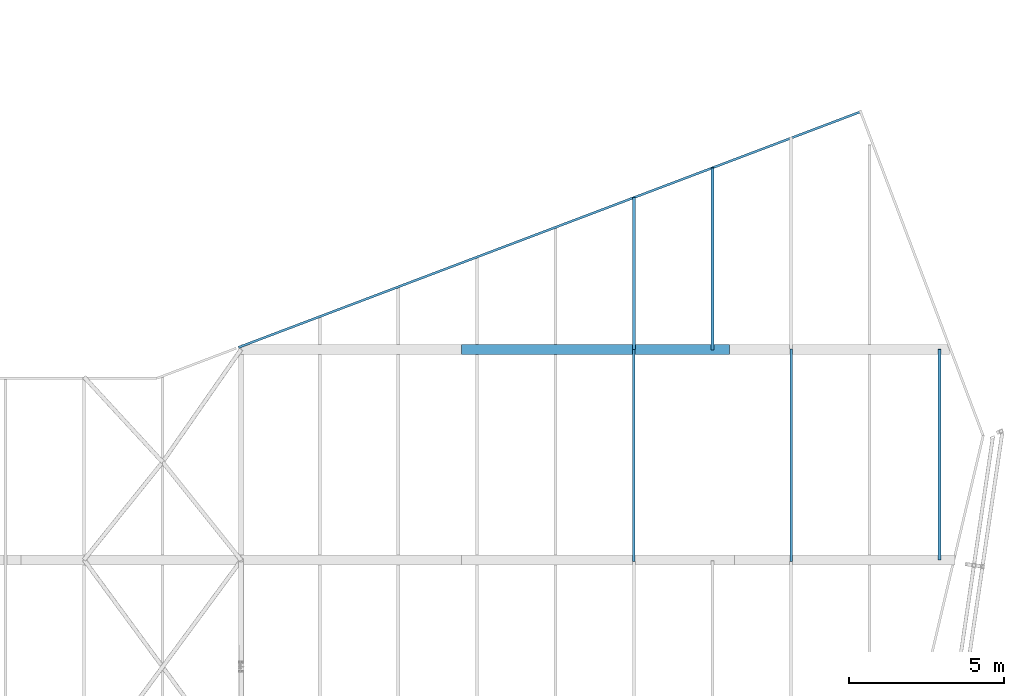
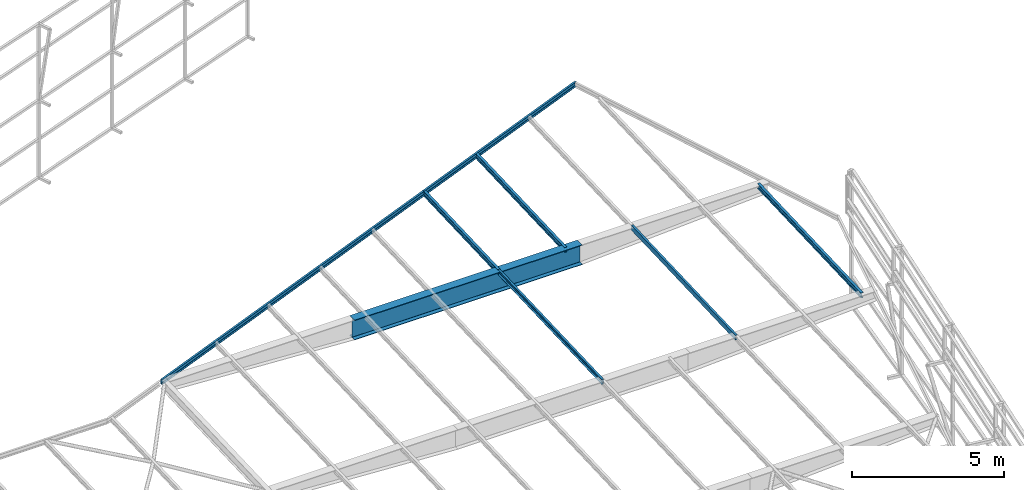
# One storey, part 135 of 215: 7 beams, 7 elements without a shape of their own.
"""IFC2X3 building model written with IfcOpenShell, lengths in millimetres."""

from ifc_helpers import new_model, si_unit, frame, origin_with_axes, origin_2d_with_axis, place, context, subcontext, project, spatial, i_section, u_section, extrude, material, type_object, element, aggregate, save


model = new_model("IFC2X3")

# Units and contexts
model_context = context("Model", 3, precision=1e-05, world=origin_with_axes())
body_context = subcontext(model_context, "Body", "Model", "MODEL_VIEW")
ifc_project = project(units=[si_unit("LENGTHUNIT", "METRE", prefix="MILLI"), si_unit("AREAUNIT", "SQUARE_METRE"), si_unit("VOLUMEUNIT", "CUBIC_METRE"), si_unit("MASSUNIT", "GRAM", prefix="KILO"), si_unit("TIMEUNIT", "SECOND"), si_unit("PLANEANGLEUNIT", "RADIAN"), si_unit("SOLIDANGLEUNIT", "STERADIAN"), si_unit("THERMODYNAMICTEMPERATUREUNIT", "DEGREE_CELSIUS"), si_unit("LUMINOUSINTENSITYUNIT", "LUMEN")], contexts=[model_context])

# Site, building, storey
site_placement = place(None, origin_with_axes())
site = spatial("IfcSite", under=ifc_project, at=site_placement, CompositionType="ELEMENT")
building_placement = place(site_placement, origin_with_axes())
building = spatial("IfcBuilding", under=site, at=building_placement, Name="Undefined", CompositionType="ELEMENT")
storey_placement = place(building_placement, origin_with_axes())
storey = spatial("IfcBuildingStorey", under=building, at=storey_placement, Name="Undefined", CompositionType="ELEMENT", Elevation=0.0)

# Assembly, beam
assembly_1_placement = place(storey_placement, origin_with_axes())
assembly_1 = element("IfcElementAssembly", 1, at=assembly_1_placement, inside=storey, Name="Steel Assembly", AssemblyPlace="NOTDEFINED", PredefinedType="RIGID_FRAME")
ifc_material_1 = material(Name="STEEL/S275JR")
beam_type_1 = type_object("IfcBeamType", Name="UPN200", PredefinedType="NOTDEFINED")
beam_1_placement = place(assembly_1_placement, frame((149587.857379477, 77085.6720608026, 4514.44590877099), z_axis=(0.0132764899953121, 0.00502865399822273, -0.999899218647745), x_axis=(-0.935072645387727, -0.354171703146857, -0.0141969200058867)))
beam_1 = element("IfcBeam", 2, at=beam_1_placement, type_object=beam_type_1, material=ifc_material_1, Name="POUTRE", ObjectType="UPN200", context=body_context, shape_type="SweptSolid", body=[
    extrude(u_section(Depth=200.0, FlangeWidth=75.0, WebThickness=8.5, FlangeThickness=11.5, FilletRadius=11.5, EdgeRadius=6.0, FlangeSlope=0.0798299857122373, at=origin_2d_with_axis()), frame((21546.3646148119, 1.17305556045591e-11, -4.54747350886464e-13), z_axis=(-1.0, 0.0, 0.0), x_axis=(-6.93889390390723e-18, -1.0, -3.46944695195361e-18)), (0.0, 0.0, 1.0), 21546.4),
])
aggregate(assembly_1, [beam_1])

assembly_2_placement = place(storey_placement, origin_with_axes())
assembly_2 = element("IfcElementAssembly", 3, at=assembly_2_placement, inside=storey, Name="Steel Assembly", AssemblyPlace="NOTDEFINED", PredefinedType="RIGID_FRAME")
beam_type_2 = type_object("IfcBeamType", Name="UPE200", PredefinedType="NOTDEFINED")
beam_2_placement = place(assembly_2_placement, frame((147305.010282576, 62535.1685916105, 3932.20431077934), z_axis=(-2.1980000026525e-06, -0.0399625230126959, 0.999201179317573), x_axis=(0.0, 0.999201183199638, 0.0399624260079844)))
beam_2 = element("IfcBeam", 4, at=beam_2_placement, type_object=beam_type_2, material=ifc_material_1, ObjectType="UPE200", context=body_context, shape_type="SweptSolid", body=[
    extrude(u_section(Depth=200.0, FlangeWidth=80.0, WebThickness=6.0, FlangeThickness=11.0, FilletRadius=13.0, at=origin_2d_with_axis()), frame((6867.75014618848, -2.91038304567337e-11, -6.82121026329696e-13), z_axis=(-1.0, 0.0, 0.0), x_axis=(-6.93889390390723e-18, -1.0, -3.46944695195361e-18)), (0.0, 0.0, 1.0), 6867.8),
])
aggregate(assembly_2, [beam_2])

assembly_3_placement = place(storey_placement, origin_with_axes())
assembly_3 = element("IfcElementAssembly", 5, at=assembly_3_placement, inside=storey, Name="Steel Assembly", AssemblyPlace="NOTDEFINED", PredefinedType="RIGID_FRAME")
beam_3_placement = place(assembly_3_placement, frame((142225.010776346, 62535.1690346318, 3932.19323950613), z_axis=(2.09399999626381e-06, 0.039962426007895, -0.999201183197447), x_axis=(0.0, 0.999201183199638, 0.0399624260079844)))
beam_3 = element("IfcBeam", 6, at=beam_3_placement, type_object=beam_type_2, material=ifc_material_1, ObjectType="UPE200", context=body_context, shape_type="SweptSolid", body=[
    extrude(u_section(Depth=200.0, FlangeWidth=80.0, WebThickness=6.0, FlangeThickness=11.0, FilletRadius=13.0, at=origin_2d_with_axis()), frame((6852.08004818157, -9.06865243442753e-20, 9.5704055824834e-13), z_axis=(-1.0, 0.0, 0.0), x_axis=(-6.93889390390723e-18, -1.0, -3.46944695195361e-18)), (0.0, 0.0, 1.0), 6852.1),
])
aggregate(assembly_3, [beam_3])

assembly_4_placement = place(storey_placement, origin_with_axes())
assembly_4 = element("IfcElementAssembly", 7, at=assembly_4_placement, inside=storey, Name="Steel Assembly", AssemblyPlace="NOTDEFINED", PredefinedType="RIGID_FRAME")
beam_type_3 = type_object("IfcBeamType", Name="IPE200", PredefinedType="NOTDEFINED")
beam_4_placement = place(assembly_4_placement, frame((142225.010783339, 69381.7755257686, 4206.01898249095), z_axis=(-2.1980000026525e-06, -0.0399625230126959, 0.999201179317573), x_axis=(0.0, 0.999201183199638, 0.0399624260079844)))
beam_4 = element("IfcBeam", 8, at=beam_4_placement, type_object=beam_type_3, material=ifc_material_1, ObjectType="IPE200", context=body_context, shape_type="SweptSolid", body=[
    extrude(i_section(OverallWidth=100.0, OverallDepth=200.0, WebThickness=5.599999905, FlangeThickness=8.5, FilletRadius=12.0, at=origin_2d_with_axis()), frame((4922.82262170191, 1.30306029814697e-19, -7.1627997020944e-13), z_axis=(-1.0, 0.0, 0.0), x_axis=(-6.93889390390723e-18, -1.0, -3.46944695195361e-18)), (0.0, 0.0, 1.0), 4922.8),
])
aggregate(assembly_4, [beam_4])

assembly_5_placement = place(storey_placement, origin_with_axes())
assembly_5 = element("IfcElementAssembly", 9, at=assembly_5_placement, inside=storey, Name="Steel Assembly", AssemblyPlace="NOTDEFINED", PredefinedType="RIGID_FRAME")
beam_5_placement = place(assembly_5_placement, frame((144765.010537178, 69372.7827998917, 4205.66486841479), z_axis=(-2.1980000026525e-06, -0.0399625230126959, 0.999201179317573), x_axis=(0.0, 0.999201183199638, 0.0399624260079844)))
beam_5 = element("IfcBeam", 10, at=beam_5_placement, type_object=beam_type_3, material=ifc_material_1, ObjectType="IPE200", context=body_context, shape_type="SweptSolid", body=[
    extrude(i_section(OverallWidth=100.0, OverallDepth=200.0, WebThickness=5.599999905, FlangeThickness=8.5, FilletRadius=12.0, at=origin_2d_with_axis()), frame((5896.98449811495, 1.56091879979726e-19, -9.50413251558333e-13), z_axis=(-1.0, 0.0, 0.0), x_axis=(-6.93889390390723e-18, -1.0, -3.46944695195361e-18)), (0.0, 0.0, 1.0), 5897.0),
])
aggregate(assembly_5, [beam_5])

assembly_6_placement = place(storey_placement, origin_with_axes())
assembly_6 = element("IfcElementAssembly", 11, at=assembly_6_placement, inside=storey, Name="Steel Assembly", AssemblyPlace="NOTDEFINED", PredefinedType="RIGID_FRAME")
beam_6_placement = place(assembly_6_placement, frame((152102.069797853, 62575.7922508772, 3933.84011734331), z_axis=(-2.1980000026525e-06, -0.0399625230126959, 0.999201179317573), x_axis=(0.0, 0.999201183199638, 0.0399624260079844)))
beam_6 = element("IfcBeam", 12, at=beam_6_placement, type_object=beam_type_3, material=ifc_material_1, ObjectType="IPE200", context=body_context, shape_type="SweptSolid", body=[
    extrude(i_section(OverallWidth=100.0, OverallDepth=200.0, WebThickness=5.599999905, FlangeThickness=8.5, FilletRadius=12.0, at=origin_2d_with_axis()), frame((6822.56405647583, 2.91038302761419e-11, 1.23155047349715e-12), z_axis=(-1.0, 0.0, 0.0), x_axis=(-6.93889390390723e-18, -1.0, -3.46944695195361e-18)), (0.0, 0.0, 1.0), 6822.6),
])
aggregate(assembly_6, [beam_6])

assembly_7_placement = place(storey_placement, origin_with_axes())
assembly_7 = element("IfcElementAssembly", 13, at=assembly_7_placement, inside=storey, Name="Steel Assembly", AssemblyPlace="NOTDEFINED", PredefinedType="RIGID_FRAME")
ifc_material_2 = material(Name="STEEL/S355JR")
beam_type_4 = type_object("IfcBeamType", PredefinedType="NOTDEFINED")
beam_7_placement = place(assembly_7_placement, frame((136647.171056435, 69388.8321925874, 3899.95301633833), z_axis=(0.0, 0.0, -1.0), x_axis=(1.0, 0.0, 0.0)))
beam_7 = element("IfcBeam", 14, at=beam_7_placement, type_object=beam_type_4, material=ifc_material_2, Name="POUTRE", context=body_context, shape_type="SweptSolid", body=[
    extrude(i_section(OverallWidth=320.0, OverallDepth=800.0, WebThickness=6.0, FlangeThickness=20.0, FilletRadius=4.2, at=origin_2d_with_axis()), frame((8661.55848855522, 0.0, 0.0), z_axis=(-1.0, 0.0, 0.0), x_axis=(-6.93889390390723e-18, -1.0, -3.46944695195361e-18)), (0.0, 0.0, 1.0), 8661.6),
])
aggregate(assembly_7, [beam_7])

save(model, "model.ifc")
